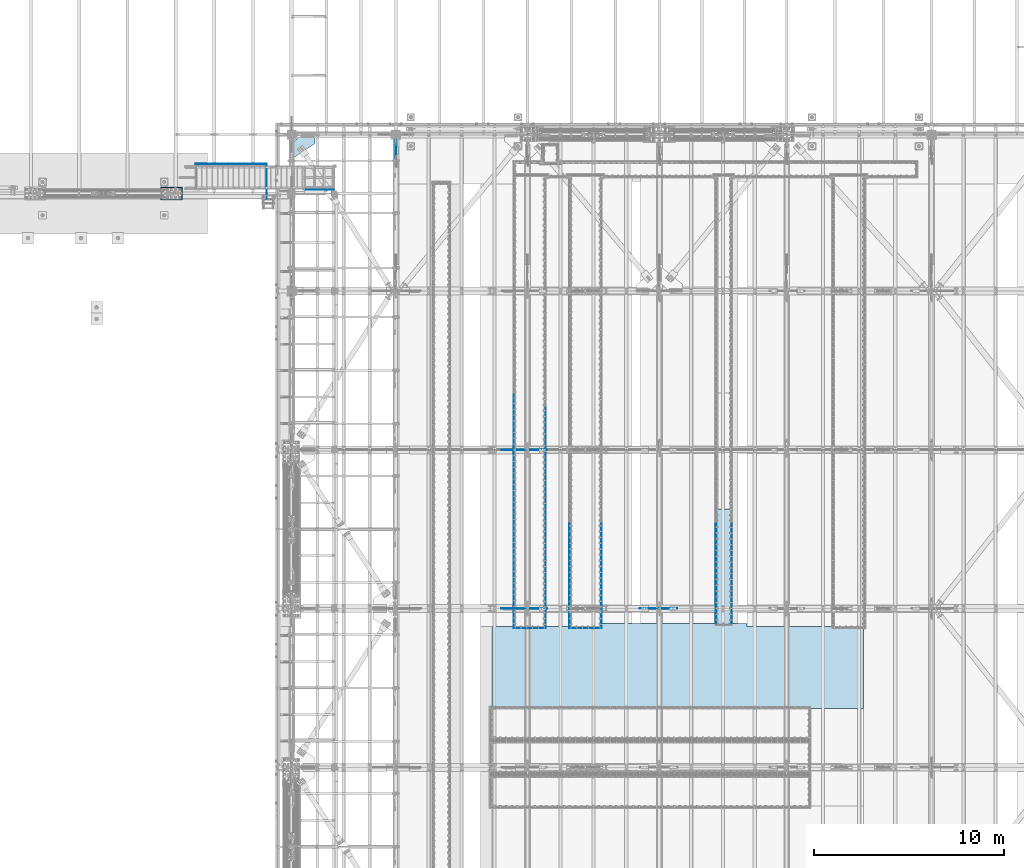
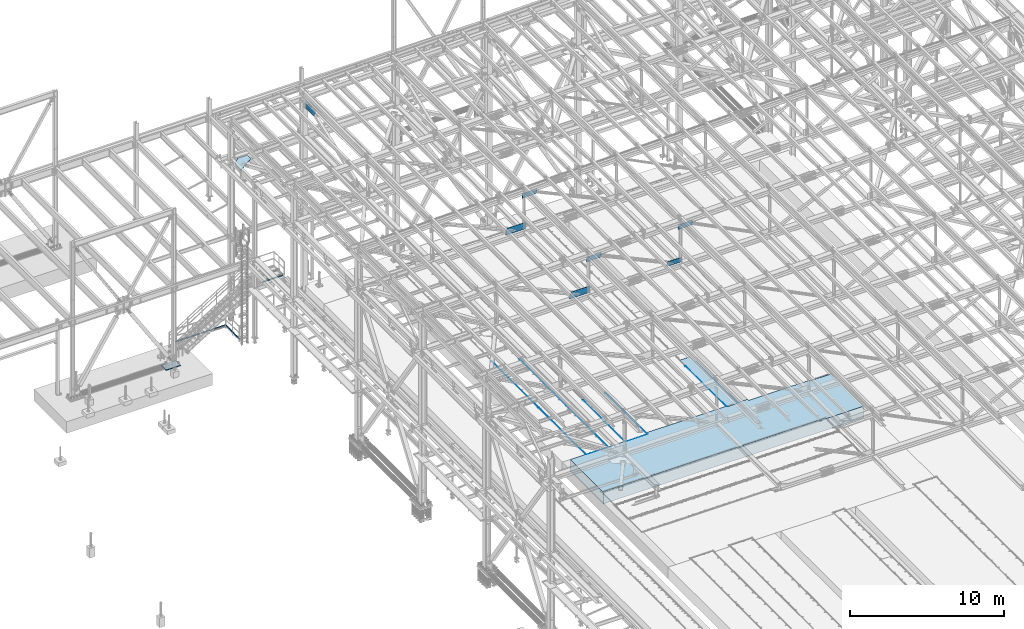
# One storey, part 2988 of 3843: 23 plates, 1 slab, 23 elements without a shape of their own.
"""IFC2X3 building model written with IfcOpenShell, lengths in millimetres."""

from ifc_helpers import new_model, si_unit, frame, origin_with_axes, place, context, subcontext, project, spatial, faceted_brep, material, type_object, element, aggregate, save


model = new_model("IFC2X3")

# Units and contexts
model_context = context("Model", 3, precision=1e-05, world=origin_with_axes())
body_context = subcontext(model_context, "Body", "Model", "MODEL_VIEW")
ifc_project = project(units=[si_unit("LENGTHUNIT", "METRE", prefix="MILLI"), si_unit("AREAUNIT", "SQUARE_METRE"), si_unit("VOLUMEUNIT", "CUBIC_METRE"), si_unit("MASSUNIT", "GRAM", prefix="KILO"), si_unit("TIMEUNIT", "SECOND"), si_unit("PLANEANGLEUNIT", "RADIAN"), si_unit("SOLIDANGLEUNIT", "STERADIAN"), si_unit("THERMODYNAMICTEMPERATUREUNIT", "DEGREE_CELSIUS"), si_unit("LUMINOUSINTENSITYUNIT", "LUMEN")], contexts=[model_context])

# Site, building, storey
site_placement = place(None, origin_with_axes())
site = spatial("IfcSite", under=ifc_project, at=site_placement, CompositionType="ELEMENT")
building_placement = place(site_placement, origin_with_axes())
building = spatial("IfcBuilding", under=site, at=building_placement, Name="Undefined", CompositionType="ELEMENT")
storey_placement = place(building_placement, origin_with_axes())
storey = spatial("IfcBuildingStorey", under=building, at=storey_placement, Name="Undefined", CompositionType="ELEMENT", Elevation=0.0)

# Assembly, plate
assembly_1_placement = place(storey_placement, origin_with_axes())
assembly_1 = element("IfcElementAssembly", 1, at=assembly_1_placement, inside=storey, Name="EMBED_ANGLE", AssemblyPlace="NOTDEFINED", PredefinedType="RIGID_FRAME")
ifc_material_1 = material(Name="STEEL/A36")
plate_type_1 = type_object("IfcPlateType", PredefinedType="NOTDEFINED")
plate_1_placement = place(assembly_1_placement, frame((48254.4116216309, 66243.3270224609, 30480.0000003815), z_axis=(1.0, 0.0, 0.0), x_axis=(0.0, 0.0, -1.0)))
plate_1 = element("IfcPlate", 2, at=plate_1_placement, type_object=plate_type_1, material=ifc_material_1, Name="PLATE", context=body_context, shape_type="Brep", body=[
    faceted_brep([(3.7862264434807e-07, 6.34999999559659, 1689.10087600505), (3.81471181754023e-07, -6.35000000444415, 1701.80092216552), (20.6374996185332, -6.35000000444415, 1701.80092216691), (25.3999996185303, -1.58749982333393, 1697.03840494261), (25.3999996185303, 6.34999999559659, 1689.10087600505), (25.3999996185303, 6.34999999997672, 12.7000860279441), (2.84853740595281e-09, 6.34999999997672, 12.7000860279441), (0.0, -6.3499999046162, 0.0), (20.6375000381231, -6.35000000004948, 2.5465851649642e-11), (25.3999996185303, -1.58750000000146, 4.76249999779975)], [[[0, 1, 2, 3, 4]], [[0, 4, 5, 6]], [[1, 0, 6, 7]], [[2, 1, 7, 8]], [[3, 2, 8, 9]], [[4, 3, 9, 5]], [[8, 7, 6, 5, 9]]]),
])
aggregate(assembly_1, [plate_1])

assembly_2_placement = place(storey_placement, origin_with_axes())
assembly_2 = element("IfcElementAssembly", 3, at=assembly_2_placement, inside=storey, Name="EMBED_ANGLE", AssemblyPlace="NOTDEFINED", PredefinedType="RIGID_FRAME")
plate_2_placement = place(assembly_2_placement, frame((51194.5254429289, 66243.327, 30480.0000003815), z_axis=(1.0, 0.0, 0.0), x_axis=(0.0, 0.0, -1.0)))
plate_2 = element("IfcPlate", 4, at=plate_2_placement, type_object=plate_type_1, material=ifc_material_1, Name="PLATE", context=body_context, shape_type="Brep", body=[
    faceted_brep([(3.78615368390456e-07, 6.34999999559659, 1689.05786711651), (3.81471181754023e-07, -6.35000000444415, 1701.80092216552), (20.6374996185332, -6.35000000444415, 1701.80092216691), (25.3999996185303, -1.58749982331938, 1697.02227654255), (25.3999996185303, 6.34999999559659, 1689.05786711651), (25.3999996185303, 6.34999999999854, 12.6999999977998), (0.0, 6.34999999999854, 12.6999998092651), (0.0, -6.3499999046162, 0.0), (20.6375000381231, -6.35000000004948, 2.5465851649642e-11), (25.3999996185303, -1.58750000000146, 4.76249999779975)], [[[0, 1, 2, 3, 4]], [[0, 4, 5, 6]], [[1, 0, 6, 7]], [[2, 1, 7, 8]], [[3, 2, 8, 9]], [[4, 3, 9, 5]], [[8, 7, 6, 5, 9]]]),
])
aggregate(assembly_2, [plate_2])

assembly_3_placement = place(storey_placement, origin_with_axes())
assembly_3 = element("IfcElementAssembly", 5, at=assembly_3_placement, inside=storey, Name="EMBED_ANGLE", AssemblyPlace="NOTDEFINED", PredefinedType="RIGID_FRAME")
plate_3_placement = place(assembly_3_placement, frame((59735.2121396484, 71735.8223125, 30479.9999992371), z_axis=(0.0, -1.0, 0.0), x_axis=(0.0, 0.0, -1.0)))
plate_3 = element("IfcPlate", 6, at=plate_3_placement, type_object=plate_type_1, material=ifc_material_1, Name="PLATE", context=body_context, shape_type="Brep", body=[
    faceted_brep([(25.3999996185303, -6.34999999999491, 2.91038304567337e-11), (0.0, -6.3499999046162, 0.0), (7.27595761418343e-12, 6.3499999046162, 0.0), (20.6374996185295, 6.35000000000218, -7.27595761418343e-12), (25.3999996185921, 1.58750000000146, 7.27595761418343e-11), (25.3999995800077, 1.58735043287743, 5341.68303603395), (25.3999996185303, -6.35000001129083, 5333.74558983232), (3.80565325031057e-07, -6.35000001129083, 5333.74558983232), (3.81471181754023e-07, 6.34999998868443, 5346.44584432112), (20.6374984696922, 6.34999998868443, 5346.44584432112)], [[[0, 1, 2, 3, 4]], [[0, 4, 5, 6]], [[1, 0, 6, 7]], [[2, 1, 7, 8]], [[3, 2, 8, 9]], [[4, 3, 9, 5]], [[8, 7, 6, 5, 9]]]),
])
aggregate(assembly_3, [plate_3])

assembly_4_placement = place(storey_placement, origin_with_axes())
assembly_4 = element("IfcElementAssembly", 7, at=assembly_4_placement, inside=storey, Name="EMBED_ANGLE", AssemblyPlace="NOTDEFINED", PredefinedType="RIGID_FRAME")
plate_4_placement = place(assembly_4_placement, frame((58909.7753603516, 71735.8223125, 30479.9999992371), z_axis=(0.0, -1.0, 0.0), x_axis=(0.0, 0.0, -1.0)))
plate_4 = element("IfcPlate", 8, at=plate_4_placement, type_object=plate_type_1, material=ifc_material_1, Name="PLATE", context=body_context, shape_type="Brep", body=[
    faceted_brep([(0.0, -6.3499999046162, 0.0), (7.27595761418343e-12, 6.3499999046162, 0.0), (25.3999999999942, 6.34999999994034, 2.91038304567337e-11), (25.3999996185921, -1.5874999999869, 7.27595761418343e-11), (20.6375000381231, -6.35000000004948, 2.5465851649642e-11), (25.3999996185521, -1.58750000003783, 5341.68280427507), (20.637498469714, -6.34999999999854, 5346.44541015624), (3.81471181754023e-07, -6.34999999999854, 5346.44541015624), (3.80565325031057e-07, 6.34999999999854, 5333.74529143325), (25.3999996185303, 6.34999999999854, 5333.74529143325)], [[[0, 1, 2, 3, 4]], [[4, 3, 5, 6]], [[0, 4, 6, 7]], [[1, 0, 7, 8]], [[2, 1, 8, 9]], [[3, 2, 9, 5]], [[8, 7, 6, 5, 9]]]),
])
aggregate(assembly_4, [plate_4])

assembly_5_placement = place(storey_placement, origin_with_axes())
assembly_5 = element("IfcElementAssembly", 9, at=assembly_5_placement, inside=storey, Name="EMBED_ANGLE", AssemblyPlace="NOTDEFINED", PredefinedType="RIGID_FRAME")
plate_5_placement = place(assembly_5_placement, frame((52889.912, 71735.822703125, 30479.9999992371), z_axis=(0.0, -1.0, 0.0), x_axis=(0.0, 0.0, -1.0)))
plate_5 = element("IfcPlate", 10, at=plate_5_placement, type_object=plate_type_1, material=ifc_material_1, Name="PLATE", context=body_context, shape_type="Brep", body=[
    faceted_brep([(25.3999996185303, -6.34999999999491, 2.91038304567337e-11), (0.0, -6.3499999046162, 0.0), (7.27595761418343e-12, 6.3499999046162, 0.0), (20.6374996185295, 6.35000000000218, -7.27595761418343e-12), (25.3999996185921, 1.58750000000146, 7.27595761418343e-11), (25.3999995800077, 1.58701656472113, 5494.03698740169), (25.3999996185303, -6.34999998514832, 5486.12906025061), (3.805871529039e-07, -6.34999998514832, 5486.12906025061), (3.81471181754023e-07, 6.34999997487466, 5498.84623475748), (20.6374984696922, 6.34999997487466, 5498.84623475748)], [[[0, 1, 2, 3, 4]], [[0, 4, 5, 6]], [[1, 0, 6, 7]], [[2, 1, 7, 8]], [[3, 2, 8, 9]], [[4, 3, 9, 5]], [[8, 7, 6, 5, 9]]]),
])
aggregate(assembly_5, [plate_5])

assembly_6_placement = place(storey_placement, origin_with_axes())
assembly_6 = element("IfcElementAssembly", 11, at=assembly_6_placement, inside=storey, Name="EMBED_ANGLE", AssemblyPlace="NOTDEFINED", PredefinedType="RIGID_FRAME")
plate_6_placement = place(assembly_6_placement, frame((51200.8754423828, 71735.8228007812, 30479.9999992371), z_axis=(0.0, -1.0, 0.0), x_axis=(0.0, 0.0, -1.0)))
plate_6 = element("IfcPlate", 12, at=plate_6_placement, type_object=plate_type_1, material=ifc_material_1, Name="PLATE", context=body_context, shape_type="Brep", body=[
    faceted_brep([(0.0, -6.3499999046162, 0.0), (7.27595761418343e-12, 6.3499999046162, 0.0), (25.3999999999942, 6.34999999994034, 2.91038304567337e-11), (25.3999996185921, -1.5874999999869, 7.27595761418343e-11), (20.6375000381231, -6.35000000004948, 2.5465851649642e-11), (25.3999996185521, -1.58750000003783, 5494.08319354089), (20.637498469714, -6.34999999999854, 5498.84580078124), (3.81471181754023e-07, -6.34999999999854, 5498.84580078124), (3.80590790882707e-07, 6.34999999999854, 5486.14568550352), (25.3999996185303, 6.34999999999854, 5486.14568550352)], [[[0, 1, 2, 3, 4]], [[4, 3, 5, 6]], [[0, 4, 6, 7]], [[1, 0, 7, 8]], [[2, 1, 8, 9]], [[3, 2, 9, 5]], [[8, 7, 6, 5, 9]]]),
])
aggregate(assembly_6, [plate_6])

assembly_7_placement = place(storey_placement, origin_with_axes())
assembly_7 = element("IfcElementAssembly", 13, at=assembly_7_placement, inside=storey, Name="EMBED_ANGLE", AssemblyPlace="NOTDEFINED", PredefinedType="RIGID_FRAME")
plate_7_placement = place(assembly_7_placement, frame((49949.8620576172, 71735.822703125, 30479.9999992371), z_axis=(0.0, -1.0, 0.0), x_axis=(0.0, 0.0, -1.0)))
plate_7 = element("IfcPlate", 14, at=plate_7_placement, type_object=plate_type_1, material=ifc_material_1, Name="PLATE", context=body_context, shape_type="Brep", body=[
    faceted_brep([(25.3999996185303, -6.34999999999491, 2.91038304567337e-11), (0.0, -6.3499999046162, 0.0), (7.27595761418343e-12, 6.3499999046162, 0.0), (20.6374996185295, 6.35000000000218, -7.27595761418343e-12), (25.3999996185921, 1.58750000000146, 7.27595761418343e-11), (25.3999995800077, 1.58752197634749, 5494.08316295042), (25.3999996185303, -6.35000000973378, 5486.14565883123), (3.80590790882707e-07, -6.35000000973378, 5486.14565883123), (3.81471181754023e-07, 6.34999999023421, 5498.84696537875), (20.6374984696922, 6.34999999023421, 5498.84696537875)], [[[0, 1, 2, 3, 4]], [[0, 4, 5, 6]], [[1, 0, 6, 7]], [[2, 1, 7, 8]], [[3, 2, 8, 9]], [[4, 3, 9, 5]], [[8, 7, 6, 5, 9]]]),
])
aggregate(assembly_7, [plate_7])

assembly_8_placement = place(storey_placement, origin_with_axes())
assembly_8 = element("IfcElementAssembly", 15, at=assembly_8_placement, inside=storey, Name="EMBED_ANGLE", AssemblyPlace="NOTDEFINED", PredefinedType="RIGID_FRAME")
plate_8_placement = place(assembly_8_placement, frame((49949.8620576172, 77831.822703125, 30479.9999996185), z_axis=(0.0, -1.0, 0.0), x_axis=(0.0, 0.0, -1.0)))
plate_8 = element("IfcPlate", 16, at=plate_8_placement, type_object=plate_type_1, material=ifc_material_1, Name="PLATE", context=body_context, shape_type="Brep", body=[
    faceted_brep([(25.399999579975, 1.58750000000873, 6096.0000061035), (25.3999996185921, 1.58750000000146, 7.27595761418343e-11), (20.6374996185295, 6.35000000000218, -7.27595761418343e-12), (20.6374984696922, 6.35000000000582, 6096.0), (0.0, -6.3499999046162, 0.0), (3.81471181754023e-07, -6.34999999999854, 6096.0), (3.81471181754023e-07, 6.34999999999854, 6096.0), (7.27595761418343e-12, 6.3499999046162, 0.0), (25.3999996185303, -6.34999999999491, 2.91038304567337e-11), (25.3999996185303, -6.35000000000582, 6096.0)], [[[0, 1, 2, 3]], [[4, 5, 6, 7]], [[8, 9, 5, 4]], [[6, 5, 9, 0, 3]], [[7, 6, 3, 2]], [[8, 4, 7, 2, 1]], [[9, 8, 1, 0]]]),
])
aggregate(assembly_8, [plate_8])

assembly_9_placement = place(storey_placement, origin_with_axes())
assembly_9 = element("IfcElementAssembly", 17, at=assembly_9_placement, inside=storey, Name="EMBED_ANGLE", AssemblyPlace="NOTDEFINED", PredefinedType="RIGID_FRAME")
plate_9_placement = place(assembly_9_placement, frame((48260.7616210937, 72421.6230224609, 30479.999999237), z_axis=(0.0, -1.0, 0.0), x_axis=(0.0, 0.0, -1.0)))
plate_9 = element("IfcPlate", 18, at=plate_9_placement, type_object=plate_type_1, material=ifc_material_1, Name="PLATE", context=body_context, shape_type="Brep", body=[
    faceted_brep([(0.0, -6.3499999046162, 0.0), (7.27595761418343e-12, 6.3499999046162, 0.0), (25.3999999999942, 6.34999999994034, 2.91038304567337e-11), (25.3999996185921, -1.5874999999869, 7.27595761418343e-11), (20.6375000381231, -6.35000000004948, 2.5465851649642e-11), (25.3999996185521, -1.58750000003783, 6179.8835222678), (20.637498469714, -6.34999999999854, 6184.646444292), (3.81471181754023e-07, -6.34999999999854, 6184.646444292), (3.80689016310498e-07, 6.34999999999854, 6171.94606133178), (25.3999996185303, 6.34999999999854, 6171.94606133178)], [[[0, 1, 2, 3, 4]], [[4, 3, 5, 6]], [[0, 4, 6, 7]], [[1, 0, 7, 8]], [[2, 1, 8, 9]], [[3, 2, 9, 5]], [[8, 7, 6, 5, 9]]]),
])
aggregate(assembly_9, [plate_9])

assembly_10_placement = place(storey_placement, origin_with_axes())
assembly_10 = element("IfcElementAssembly", 19, at=assembly_10_placement, inside=storey, Name="EMBED_ANGLE", AssemblyPlace="NOTDEFINED", PredefinedType="RIGID_FRAME")
plate_10_placement = place(assembly_10_placement, frame((48260.7616210937, 78517.6230224609, 30479.9999996185), z_axis=(0.0, -1.0, 0.0), x_axis=(0.0, 0.0, -1.0)))
plate_10 = element("IfcPlate", 20, at=plate_10_placement, type_object=plate_type_1, material=ifc_material_1, Name="PLATE", context=body_context, shape_type="Brep", body=[
    faceted_brep([(25.3999996185521, -1.58750000003783, 6096.0), (20.6375003814719, -6.34999999999854, 6096.00000000139), (20.6375000381231, -6.35000000004948, 2.5465851649642e-11), (25.3999996185921, -1.5874999999869, 7.27595761418343e-11), (0.0, -6.3499999046162, 0.0), (3.81471181754023e-07, -6.34999999999854, 6096.0), (3.81471181754023e-07, 6.34999999999854, 6096.0), (7.27595761418343e-12, 6.3499999046162, 0.0), (25.3999996185303, 6.34999999999854, 6096.00000000171), (25.3999999999942, 6.34999999994034, 2.91038304567337e-11)], [[[0, 1, 2, 3]], [[4, 5, 6, 7]], [[8, 9, 7, 6]], [[9, 8, 0, 3]], [[4, 7, 9, 3, 2]], [[5, 4, 2, 1]], [[8, 6, 5, 1, 0]]]),
])
aggregate(assembly_10, [plate_10])

assembly_11_placement = place(storey_placement, origin_with_axes())
assembly_11 = element("IfcElementAssembly", 21, at=assembly_11_placement, inside=storey, Name="PLATE", AssemblyPlace="NOTDEFINED", PredefinedType="RIGID_FRAME")
ifc_material_2 = material(Name="STEEL/A572-50")
plate_type_2 = type_object("IfcPlateType", PredefinedType="NOTDEFINED")
plate_11_placement = place(assembly_11_placement, frame((58922.43284359, 66408.4259205605, 30467.3), z_axis=(0.0, 1.0, 0.0), x_axis=(1.0, 0.0, 0.0)))
plate_11 = element("IfcPlate", 22, at=plate_11_placement, type_object=plate_type_2, material=ifc_material_2, Name="PLATE", context=body_context, shape_type="Brep", body=[
    faceted_brep([(0.0, -12.6999999999971, 0.0), (0.00815935323043959, -12.7000000000007, 6111.87505718063), (0.00815935323043959, 12.7000000000007, 6111.87505718063), (0.0, 12.6999999999971, 0.0), (800.105437834325, -12.7000000000007, 6111.87548573336), (800.105437834325, 12.7000000000007, 6111.87548573336), (800.097278482099, -12.7000000000007, 0.0), (800.097278482099, 12.7000000000007, 0.0)], [[[0, 1, 2, 3]], [[1, 4, 5, 2]], [[4, 6, 7, 5]], [[6, 0, 3, 7]], [[5, 7, 3, 2]], [[6, 4, 1, 0]]]),
])
aggregate(assembly_11, [plate_11])

assembly_12_placement = place(storey_placement, origin_with_axes())
assembly_12 = element("IfcElementAssembly", 23, at=assembly_12_placement, inside=storey, Name="BEAM", AssemblyPlace="NOTDEFINED", PredefinedType="RIGID_FRAME")
plate_type_3 = type_object("IfcPlateType", PredefinedType="NOTDEFINED")
plate_12_placement = place(assembly_12_placement, frame((37268.6556414911, 89315.9248753107, 34042.3499608327), z_axis=(0.0, 0.0, 1.0), x_axis=(0.99999999971363, -2.39319999927239e-05, 0.0)))
plate_12 = element("IfcPlate", 24, at=plate_12_placement, type_object=plate_type_3, material=ifc_material_2, Name="PLATE", context=body_context, shape_type="Brep", body=[
    faceted_brep([(4.36557456851006e-11, -3.17499999998836, 19.0499992370969), (0.0, -3.17499999999927, 95.25), (-2.44140610448085e-05, 3.17500000000291, 95.2499999999927), (1.45519152283669e-11, 3.17499999998836, 19.0499992370824), (1520.32179213777, -3.17500001066946, 95.2499999948777), (1520.32179213777, 3.17499998930725, 95.2499999948777), (1520.32179213779, -3.17500001066946, 19.0499992319383), (1520.32179213779, 3.17499998930725, 19.0499992319383), (1501.2717929007, -3.1750000105385, -5.05679054185748e-09), (1501.27179290069, 3.17499998942367, -5.05679054185748e-09), (19.0499992370023, -3.17500000005384, 0.0), (19.0499992369587, 3.17499999992287, -1.45519152283669e-11)], [[[0, 1, 2, 3]], [[1, 4, 5, 2]], [[4, 6, 7, 5]], [[6, 8, 9, 7]], [[8, 10, 11, 9]], [[10, 0, 3, 11]], [[5, 7, 9, 11, 3, 2]], [[10, 8, 6, 4, 1, 0]]]),
])
aggregate(assembly_12, [plate_12])

# Assembly, plates
assembly_13_placement = place(storey_placement, origin_with_axes())
assembly_13 = element("IfcElementAssembly", 25, at=assembly_13_placement, inside=storey, Name="RAIL", AssemblyPlace="NOTDEFINED", PredefinedType="RIGID_FRAME")
plate_type_4 = type_object("IfcPlateType", PredefinedType="NOTDEFINED")
plate_13_placement = place(assembly_13_placement, frame((35277.4250000271, 88842.85, 30492.7), z_axis=(0.0, 0.0, 1.0), x_axis=(0.0, 1.0, 0.0)))
plate_13 = element("IfcPlate", 26, at=plate_13_placement, type_object=plate_type_4, material=ifc_material_1, Name="TOE_PLATE", context=body_context, shape_type="Brep", body=[
    faceted_brep([(0.0, -3.17499999999927, 0.0), (0.0, -3.17499999999927, 101.600000000006), (0.0, 3.17499999999927, 101.600000000006), (0.0, 3.17499999999927, 0.0), (1822.45000000965, -3.17500000000291, 101.599999999999), (1822.45000000965, 3.17500000000291, 101.599999999999), (1822.45000000965, -3.17500000000291, 0.0), (1822.45000000965, 3.17500000000291, 0.0)], [[[0, 1, 2, 3]], [[1, 4, 5, 2]], [[4, 6, 7, 5]], [[6, 0, 3, 7]], [[5, 7, 3, 2]], [[6, 4, 1, 0]]]),
])
plate_14_placement = place(assembly_13_placement, frame((35274.2500000271, 90668.4750000097, 30492.7), z_axis=(0.0, 0.0, 1.0), x_axis=(-1.0, 0.0, 0.0)))
plate_14 = element("IfcPlate", 27, at=plate_14_placement, type_object=plate_type_4, material=ifc_material_1, Name="TOE_PLATE", context=body_context, shape_type="Brep", body=[
    faceted_brep([(0.0, -3.17499999999927, 0.0), (0.0, -3.17499999999927, 101.600000000006), (0.0, 3.17499999999927, 101.600000000006), (0.0, 3.17499999999927, 0.0), (3746.50000000001, -3.17500000000291, 101.599999999999), (3746.50000000001, 3.17500000000291, 101.599999999999), (3746.50000000001, -3.17500000000291, 0.0), (3746.50000000001, 3.17500000000291, 0.0)], [[[0, 1, 2, 3]], [[1, 4, 5, 2]], [[4, 6, 7, 5]], [[6, 0, 3, 7]], [[5, 7, 3, 2]], [[6, 4, 1, 0]]]),
])
aggregate(assembly_13, [plate_13, plate_14])

# Assembly, plate
assembly_14_placement = place(storey_placement, origin_with_axes())
assembly_14 = element("IfcElementAssembly", 28, at=assembly_14_placement, inside=storey, Name="PLATE", AssemblyPlace="NOTDEFINED", PredefinedType="RIGID_FRAME")
plate_type_5 = type_object("IfcPlateType", PredefinedType="NOTDEFINED")
plate_15_placement = place(assembly_14_placement, frame((36580.7625000004, 91732.1, 42232.2630004883), z_axis=(1.0, 0.0, 0.0), x_axis=(0.0, -1.0, 0.0)))
plate_15 = element("IfcPlate", 29, at=plate_15_placement, type_object=plate_type_5, material=ifc_material_2, Name="PLATE", context=body_context, shape_type="Brep", body=[
    faceted_brep([(0.0, -14.2874999999985, 0.0), (-476.250000048109, -14.2874999999985, 477.83749997773), (-476.250000048109, 14.2874999999985, 477.83749997773), (0.0, 14.2874999999985, 0.0), (-476.250000048109, -14.2874999999985, 1214.43749997662), (-476.250000048109, 14.2874999999985, 1214.43749997662), (-12.7000000002154, -14.2874999999985, 1214.43749999988), (-12.7000000002154, 14.2874999999985, 1214.43749999988), (736.599999999991, -14.2874999999985, 90.4874999995809), (736.599999999991, 14.2874999999985, 90.4874999995809), (736.599999940488, -14.2874999999985, 0.0), (736.599999940488, 14.2874999999985, 0.0)], [[[0, 1, 2, 3]], [[1, 4, 5, 2]], [[4, 6, 7, 5]], [[6, 8, 9, 7]], [[8, 10, 11, 9]], [[10, 0, 3, 11]], [[5, 7, 9, 11, 3, 2]], [[10, 8, 6, 4, 1, 0]]]),
])
aggregate(assembly_14, [plate_15])

assembly_15_placement = place(storey_placement, origin_with_axes())
assembly_15 = element("IfcElementAssembly", 30, at=assembly_15_placement, inside=storey, Name="PLATE", AssemblyPlace="NOTDEFINED", PredefinedType="RIGID_FRAME")
plate_type_6 = type_object("IfcPlateType", PredefinedType="NOTDEFINED")
plate_16_placement = place(assembly_15_placement, frame((42062.4, 92036.899999972, 45173.5133418351), z_axis=(0.0, 0.0, -1.0), x_axis=(0.0, -1.0, 0.0)))
plate_16 = element("IfcPlate", 31, at=plate_16_placement, type_object=plate_type_6, material=ifc_material_2, Name="PLATE", context=body_context, shape_type="Brep", body=[
    faceted_brep([(0.0, -7.9375, 0.0), (8.36735125631094e-09, -7.9375, 574.317235894952), (8.36735125631094e-09, 7.9375, 574.317235894952), (0.0, 7.9375, 0.0), (1144.93094247299, -7.9375, 574.317235878298), (1144.93094247299, 7.9375, 574.317235878298), (1301.22259113181, -7.9375, 158.200460730368), (1301.22259113181, 7.9375, 158.200460730368), (1301.22259113179, -7.9375, -7.27595761418343e-12), (1301.22259113179, 7.9375, -7.27595761418343e-12)], [[[0, 1, 2, 3]], [[1, 4, 5, 2]], [[4, 6, 7, 5]], [[6, 8, 9, 7]], [[8, 0, 3, 9]], [[5, 7, 9, 3, 2]], [[8, 6, 4, 1, 0]]]),
])
aggregate(assembly_15, [plate_16])

assembly_16_placement = place(storey_placement, origin_with_axes())
assembly_16 = element("IfcElementAssembly", 32, at=assembly_16_placement, inside=storey, Name="BEAM", AssemblyPlace="NOTDEFINED", PredefinedType="RIGID_FRAME")
plate_type_7 = type_object("IfcPlateType", PredefinedType="NOTDEFINED")
plate_17_placement = place(assembly_16_placement, frame((56871.5769419586, 67271.9, 45538.1250121546), z_axis=(0.0235721709946665, 0.0, -0.999722137773591), x_axis=(-0.999722137773591, 0.0, -0.0235721709946646)))
plate_17 = element("IfcPlate", 33, at=plate_17_placement, type_object=plate_type_7, material=ifc_material_2, Name="PLATE", context=body_context, shape_type="Brep", body=[
    faceted_brep([(0.0, -9.52500000000146, 0.0), (-5.3114490583539e-10, -9.52499999999418, 171.932699986966), (-5.3114490583539e-10, 9.52499999999418, 171.932699986966), (0.0, 9.52500000000146, 0.0), (107.497605282522, -9.52499999999418, 373.680624694658), (107.497605282522, 9.52499999999418, 373.680624694658), (1121.34698561319, -9.52499999999418, 373.680624697889), (1121.34698561319, 9.52499999999418, 373.680624697889), (1112.53607372141, -9.52499999999418, 3.56521923094988e-09), (1112.53607372141, 9.52499999999418, 3.56521923094988e-09)], [[[0, 1, 2, 3]], [[1, 4, 5, 2]], [[4, 6, 7, 5]], [[6, 8, 9, 7]], [[8, 0, 3, 9]], [[5, 7, 9, 3, 2]], [[8, 6, 4, 1, 0]]]),
])
aggregate(assembly_16, [plate_17])

assembly_17_placement = place(storey_placement, origin_with_axes())
assembly_17 = element("IfcElementAssembly", 34, at=assembly_17_placement, inside=storey, Name="BEAM", AssemblyPlace="NOTDEFINED", PredefinedType="RIGID_FRAME")
plate_type_8 = type_object("IfcPlateType", PredefinedType="NOTDEFINED")
plate_18_placement = place(assembly_17_placement, frame((50019.7436106022, 67271.9, 45373.7994526288), z_axis=(0.0248927260021373, 0.0, -0.99969012808579), x_axis=(-0.99969012808579, 0.0, -0.0248927260021355)))
plate_18 = element("IfcPlate", 35, at=plate_18_placement, type_object=plate_type_8, material=ifc_material_2, Name="PLATE", context=body_context, shape_type="Brep", body=[
    faceted_brep([(0.0, -9.52500000000146, 0.0), (-2.11002770811319e-10, -9.52499999999418, 136.606684034465), (-2.11002770811319e-10, 9.52499999999418, 136.606684034465), (0.0, 9.52500000000146, 0.0), (112.579413970983, -9.52499999999418, 364.294796795039), (112.579413970983, 9.52499999999418, 364.294796795039), (1146.83986140571, -9.52499999999418, 364.294796796639), (1146.83986140571, 9.52499999999418, 364.294796796639), (1138.15688719563, -9.52499999999418, 1.75350578501821e-09), (1138.15688719563, 9.52499999999418, 1.75350578501821e-09)], [[[0, 1, 2, 3]], [[1, 4, 5, 2]], [[4, 6, 7, 5]], [[6, 8, 9, 7]], [[8, 0, 3, 9]], [[5, 7, 9, 3, 2]], [[8, 6, 4, 1, 0]]]),
])
aggregate(assembly_17, [plate_18])

assembly_18_placement = place(storey_placement, origin_with_axes())
assembly_18 = element("IfcElementAssembly", 36, at=assembly_18_placement, inside=storey, Name="BEAM", AssemblyPlace="NOTDEFINED", PredefinedType="RIGID_FRAME")
plate_19_placement = place(assembly_18_placement, frame((49996.2625805779, 75628.5, 45363.4026617018), z_axis=(0.024279608996163, 0.0, -0.999705206841994), x_axis=(-0.999705206841994, 0.0, -0.0242796089961599)))
plate_19 = element("IfcPlate", 37, at=plate_19_placement, type_object=plate_type_8, material=ifc_material_2, Name="PLATE", context=body_context, shape_type="Brep", body=[
    faceted_brep([(0.0, -9.52500000000146, 0.0), (1.38243194669485e-10, -9.52499999999418, 181.503443781279), (1.38243194669485e-10, 9.52499999999418, 181.503443781279), (0.0, 9.52500000000146, 0.0), (90.0341728997737, -9.52499999999418, 363.668447813696), (90.0341728997737, 9.52499999999418, 363.668447813696), (1123.10027088767, -9.52499999999418, 363.668447812903), (1123.10027088767, 9.52499999999418, 363.668447812903), (1114.60433391876, -9.52499999999418, -8.51287040859461e-10), (1114.60433391876, 9.52499999999418, -8.51287040859461e-10)], [[[0, 1, 2, 3]], [[1, 4, 5, 2]], [[4, 6, 7, 5]], [[6, 8, 9, 7]], [[8, 0, 3, 9]], [[5, 7, 9, 3, 2]], [[8, 6, 4, 1, 0]]]),
])
aggregate(assembly_18, [plate_19])

assembly_19_placement = place(storey_placement, origin_with_axes())
assembly_19 = element("IfcElementAssembly", 38, at=assembly_19_placement, inside=storey, Name="BEAM", AssemblyPlace="NOTDEFINED", PredefinedType="RIGID_FRAME")
plate_type_9 = type_object("IfcPlateType", PredefinedType="NOTDEFINED")
plate_20_placement = place(assembly_19_placement, frame((56045.9853348457, 67271.9, 42513.1723404734), z_axis=(-0.00249667500075157, 0.0, 0.999996883302113), x_axis=(-0.999996883302113, 0.0, -0.00249667500075423)))
plate_20 = element("IfcPlate", 39, at=plate_20_placement, type_object=plate_type_9, material=ifc_material_2, Name="PLATE", context=body_context, shape_type="Brep", body=[
    faceted_brep([(0.0, -9.52500000000146, 0.0), (-6.83940015733242e-10, -9.52499999999418, 354.605075886371), (-6.83940015733242e-10, 9.52499999999418, 354.605075886371), (0.0, 9.52500000000146, 0.0), (1034.2690805869, -9.52499999999418, 357.18731807798), (1034.2690805869, 9.52499999999418, 357.18731807798), (1141.72078242197, -9.52499999999418, 127.034905718006), (1141.72078242197, 9.52499999999418, 127.034905718006), (1141.72078242223, -9.52499999999418, 2.17551132664084e-09), (1141.72078242223, 9.52499999999418, 2.17551132664084e-09)], [[[0, 1, 2, 3]], [[1, 4, 5, 2]], [[4, 6, 7, 5]], [[6, 8, 9, 7]], [[8, 0, 3, 9]], [[5, 7, 9, 3, 2]], [[8, 6, 4, 1, 0]]]),
])
aggregate(assembly_19, [plate_20])

assembly_20_placement = place(storey_placement, origin_with_axes())
assembly_20 = element("IfcElementAssembly", 40, at=assembly_20_placement, inside=storey, Name="BEAM", AssemblyPlace="NOTDEFINED", PredefinedType="RIGID_FRAME")
plate_type_10 = type_object("IfcPlateType", PredefinedType="NOTDEFINED")
plate_21_placement = place(assembly_20_placement, frame((49112.8345923023, 67271.9, 42492.0297180323), z_axis=(-0.00382132899883437, 0.0, 0.999992698695687), x_axis=(-0.999992698695687, 0.0, -0.0038213289988363)))
plate_21 = element("IfcPlate", 41, at=plate_21_placement, type_object=plate_type_10, material=ifc_material_2, Name="PLATE", context=body_context, shape_type="Brep", body=[
    faceted_brep([(0.0, -9.52500000000146, 0.0), (-1.73895386978984e-09, -9.52499999999418, 507.849371509044), (-1.73895386978984e-09, 9.52499999999418, 507.849371509044), (0.0, 9.52500000000146, 0.0), (1368.05858711807, -9.52499999999418, 513.077213347562), (1368.05858711807, 9.52499999999418, 513.077213347562), (1492.19421796136, -9.52499999999418, 234.700875059541), (1492.19421796136, 9.52499999999418, 234.700875059541), (1492.19421796216, -9.52499999999418, 5.10772224515676e-09), (1492.19421796216, 9.52499999999418, 5.10772224515676e-09)], [[[0, 1, 2, 3]], [[1, 4, 5, 2]], [[4, 6, 7, 5]], [[6, 8, 9, 7]], [[8, 0, 3, 9]], [[5, 7, 9, 3, 2]], [[8, 6, 4, 1, 0]]]),
])
aggregate(assembly_20, [plate_21])

assembly_21_placement = place(storey_placement, origin_with_axes())
assembly_21 = element("IfcElementAssembly", 42, at=assembly_21_placement, inside=storey, Name="BEAM", AssemblyPlace="NOTDEFINED", PredefinedType="RIGID_FRAME")
plate_type_11 = type_object("IfcPlateType", PredefinedType="NOTDEFINED")
plate_22_placement = place(assembly_21_placement, frame((49112.5236684681, 75628.5, 42483.0704971857), z_axis=(-0.00319954200145003, 0.0, 0.999994881452391), x_axis=(-0.999994881452391, 0.0, -0.00319954200144788)))
plate_22 = element("IfcPlate", 43, at=plate_22_placement, type_object=plate_type_11, material=ifc_material_2, Name="PLATE", context=body_context, shape_type="Brep", body=[
    faceted_brep([(0.0, -9.52500000000146, 0.0), (7.27595761418343e-12, -9.52499999999418, 507.523980125523), (7.27595761418343e-12, 9.52499999999418, 507.523980125523), (0.0, 9.52500000000146, 0.0), (1365.9456252306, -9.52499999999418, 511.893929622878), (1365.9456252306, 9.52499999999418, 511.893929622878), (1469.38114676873, -9.52499999999418, 279.908813830596), (1469.38114676873, 9.52499999999418, 279.908813830596), (1469.38114676872, -9.52499999999418, -2.91038304567337e-11), (1469.38114676872, 9.52499999999418, -2.91038304567337e-11)], [[[0, 1, 2, 3]], [[1, 4, 5, 2]], [[4, 6, 7, 5]], [[6, 8, 9, 7]], [[8, 0, 3, 9]], [[5, 7, 9, 3, 2]], [[8, 6, 4, 1, 0]]]),
])
aggregate(assembly_21, [plate_22])

# Assembly, slab
assembly_22_placement = place(storey_placement, origin_with_axes())
assembly_22 = element("IfcElementAssembly", 44, at=assembly_22_placement, inside=storey, Name="SLAB", AssemblyPlace="NOTDEFINED", PredefinedType="REINFORCEMENT_UNIT")
ifc_material_3 = material(Name="CONCRETE/3000")
slab_type = type_object("IfcSlabType", PredefinedType="NOTDEFINED")
slab_placement = place(assembly_22_placement, frame((47111.4119790039, 66325.877734375, 30022.8), z_axis=(1.0, 0.0, 0.0), x_axis=(0.0, -1.0, 0.0)))
slab = element("IfcSlab", 45, at=slab_placement, type_object=slab_type, material=ifc_material_3, Name="SLAB", PredefinedType="FLOOR", context=body_context, shape_type="Brep", body=[
    faceted_brep([(0.000444290824816562, -431.799999595256, 1155.69964433225), (76.2011562050611, -431.800000738218, 1155.69964433225), (76.2011645964085, -431.799999061066, 2832.1000581012), (0.000832080782856792, -431.799997918108, 2832.1000785231), (76.2011558239901, -457.200000000001, 1155.69964435757), (0.0, -457.200000000001, 1155.69964435757), (76.2011642153375, -457.200000000001, 2832.10005812652), (0.0, -457.200000000001, 2832.10007854842), (-152.399168074946, -431.799999618546, 11804.7133813115), (-76.1991722250386, -431.800000761501, 11804.7133813121), (-76.1988380971015, -431.800000761497, 12617.450121163), (-152.399167970405, -431.799999618539, 12617.4501606345), (-76.1991726061242, -457.200000000001, 11804.7133813121), (-152.399261474609, -457.200000000001, 11804.7133813115), (-76.1988384781725, -457.200000000001, 12617.450121163), (-152.399261474609, -457.200000000001, 12617.4501606345), (-152.399261474609, 457.200000000001, 5695.9501953125), (0.0, 457.200000000001, 5695.9501953125), (0.0, -431.80000000001, 5695.9501953125), (-152.399261474609, -431.80000000001, 5695.9501953125), (-1.16269802674651e-08, -431.800024001081, 4095.81346561847), (76.2007343633741, -431.800024001081, 4095.813465614), (76.2011870417628, -431.799998857063, 5772.14995963134), (-152.399262922743, -431.799998857063, 5772.1500209102), (76.2007343633741, -457.200000000001, 4095.81346599507), (0.0, -457.200000000001, 4095.81346599954), (76.2011870417628, -457.200000000001, 5772.14996001242), (-152.399261474609, -457.200000000001, 5772.15002129128), (-152.399261474609, -457.200000000001, 13423.900390625), (-152.399261474609, 457.200000000001, 13423.900390625), (0.000734375033061951, 457.200000000001, 13423.900390625), (0.000734375033061951, 457.200000000001, 19558.0), (4321.302734375, 457.200000000001, 19558.0), (4321.302734375, 457.200000000001, 0.0), (0.0, 457.200000000001, 0.0), (0.000734375033061951, -457.200000000001, 13423.900390625), (0.000734375033061951, -431.800000762934, 19558.0), (0.000832024641567841, -431.800000762934, 17957.8635766527), (76.2007377719856, -431.800000762934, 17957.8635562376), (76.2011664730526, -431.800000762934, 19558.0000210251), (0.000734375033061951, -457.200000000001, 17957.8635766527), (76.2007377719856, -457.200000000001, 17957.8635562376), (76.2011664730526, -457.200000000001, 19558.0000210251), (4321.302734375, -457.200000000001, 19558.0), (4321.302734375, -431.799998239079, 0.0), (4321.30273766341, -457.200000000001, 16751.3000209837), (4321.3027368253, -431.799998242066, 16751.3000209837), (4245.10273766342, -457.200000000001, 16751.3000209948), (4245.10273682531, -431.800000756673, 16751.3000209948), (4245.1027352258, -457.200000000001, 0.0), (4245.10273438768, -431.80000075369, 0.000411606808484066), (0.0, -457.200000000001, 0.0)], [[[0, 1, 2, 3]], [[4, 1, 0, 5]], [[6, 2, 1, 4]], [[7, 3, 2, 6]], [[8, 9, 10, 11]], [[12, 9, 8, 13]], [[14, 10, 9, 12]], [[15, 11, 10, 14]], [[16, 17, 18, 19]], [[18, 20, 21, 22, 23, 19]], [[24, 21, 20, 25]], [[26, 22, 21, 24]], [[27, 23, 22, 26]], [[13, 8, 11, 15, 28, 29, 16, 19, 23, 27]], [[16, 29, 30, 31, 32, 33, 34, 17]], [[28, 35, 30, 29]], [[36, 37, 38, 39]], [[31, 30, 35, 40, 37, 36]], [[41, 38, 37, 40]], [[42, 39, 38, 41]], [[43, 32, 31, 36, 39, 42]], [[44, 33, 32, 43, 45, 46]], [[45, 47, 48, 46]], [[49, 50, 48, 47]], [[46, 48, 50, 44]], [[49, 51, 34, 33, 44, 50]], [[25, 20, 18, 17, 34, 51, 5, 0, 3, 7]], [[5, 51, 49, 47, 45, 43, 42, 41, 40, 35, 28, 15, 14, 12, 13, 27, 26, 24, 25, 7, 6, 4]]]),
])
aggregate(assembly_22, [slab])

# Assembly, plate
assembly_23_placement = place(storey_placement, origin_with_axes())
assembly_23 = element("IfcElementAssembly", 46, at=assembly_23_placement, inside=storey, Name="GROUT", AssemblyPlace="NOTDEFINED", PredefinedType="REINFORCEMENT_UNIT")
ifc_material_4 = material(Name="CONCRETE/Concrete_Undefined")
plate_type_12 = type_object("IfcPlateType", PredefinedType="NOTDEFINED")
plate_23_placement = place(assembly_23_placement, frame((29679.9, 88773.0, 30041.85), z_axis=(0.0, 1.0, 0.0), x_axis=(1.0, 0.0, 0.0)))
plate_23 = element("IfcPlate", 47, at=plate_23_placement, type_object=plate_type_12, material=ifc_material_4, Name="GROUT", context=body_context, shape_type="Brep", body=[
    faceted_brep([(38.0999999997803, -19.0499999997846, 647.699999999328), (0.0, 19.0499999999993, 685.799987792969), (0.0, 19.0500000000029, 0.0), (38.1000000006916, -19.0499999999811, 38.1000000006607), (1104.90000000021, -19.0499999998137, 38.1000000006607), (1143.0, 19.0499999999993, 0.0), (1143.0, 19.0499999999993, 685.799987792969), (1104.90000000021, -19.0499999999884, 647.699999999328)], [[[0, 1, 2, 3]], [[4, 5, 6, 7]], [[4, 7, 0, 3]], [[5, 4, 3, 2]], [[6, 5, 2, 1]], [[7, 6, 1, 0]]]),
])
aggregate(assembly_23, [plate_23])

save(model, "model.ifc")
